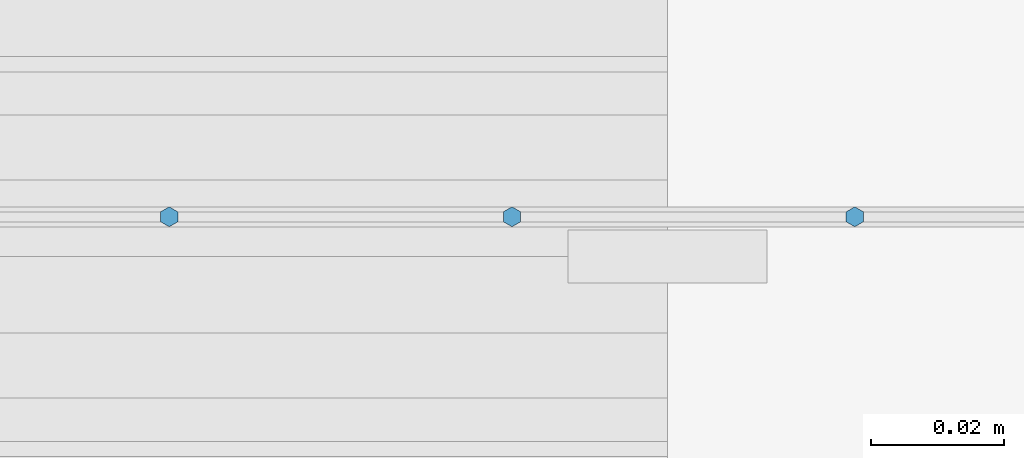
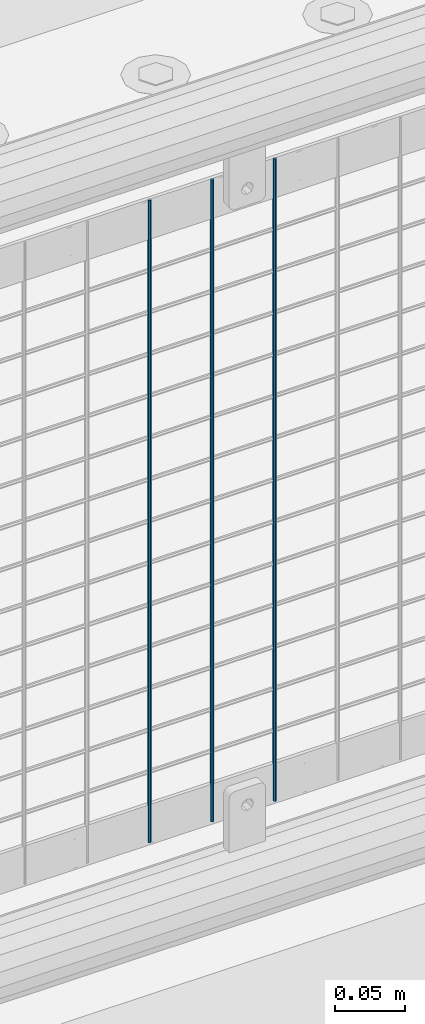
# One storey, part 81 of 240: 3 columns.
"""IFC2X3 building model written with IfcOpenShell, lengths in millimetres."""

import ifcopenshell
import ifcopenshell.guid

model = None  # the IFC model being written
_history = None  # IfcOwnerHistory: only IFC2X3 demands one
_inside = {}  # id of a spatial element -> (the spatial element, [elements in it])
_under = {}  # id of a project, library or spatial element -> (it, [spatial elements below it])
_declared = {}  # id of a project -> (the project, [libraries it declares])
_typed = {}  # id of a type object -> (the type object, [elements of that type])
_made_of = {}  # id of a material, layer set ... -> (it, [elements and type objects made of it])


def new_model(schema):
    """Start an empty IFC model of exactly this schema.

    Asked for "IFC4X3", IfcOpenShell would pick the latest addendum, in which some entities
    have other attributes; the version numbers below select the first issue.
    IFC2X3 requires an IfcOwnerHistory on every rooted entity: one is made here for all.
    """
    global model, _history
    if schema == "IFC4X3":
        model = ifcopenshell.file(schema_version=(4, 3, 0, 0))
    else:
        model = ifcopenshell.file(schema=schema)
    _inside.clear()
    _under.clear()
    _declared.clear()
    _typed.clear()
    _made_of.clear()
    _history = None
    if model.schema == "IFC2X3":
        org = make("IfcOrganization", Name="unknown")
        user = make(
            "IfcPersonAndOrganization",
            ThePerson=make("IfcPerson", FamilyName="unknown"),
            TheOrganization=org,
        )
        app = make(
            "IfcApplication",
            ApplicationDeveloper=org,
            Version="unknown",
            ApplicationFullName="unknown",
            ApplicationIdentifier="unknown",
        )
        _history = make(
            "IfcOwnerHistory",
            OwningUser=user,
            OwningApplication=app,
            ChangeAction="ADDED",
            CreationDate=0,
        )
    return model


def make(cls, **values):
    """One entity of the class cls with the attributes given. An attribute that is None is left unset."""
    return model.create_entity(
        cls, **{name: value for name, value in values.items() if value is not None}
    )


def rooted(cls, **values):
    """An entity with a GlobalId (a new one), such as an element, a storey or a relation."""
    return make(cls, GlobalId=ifcopenshell.guid.new(), OwnerHistory=_history, **values)


def si_unit(unit_type, name, prefix=None):
    """IfcSIUnit, for example si_unit("LENGTHUNIT", "METRE", prefix="MILLI")."""
    return make("IfcSIUnit", UnitType=unit_type, Prefix=prefix, Name=name)


def assignment(units):
    """IfcUnitAssignment: the units of a project."""
    return None if units is None else make("IfcUnitAssignment", Units=units)


def point(xyz):
    """IfcCartesianPoint."""
    return None if xyz is None else make("IfcCartesianPoint", Coordinates=xyz)


def direction(xyz):
    """IfcDirection."""
    return None if xyz is None else make("IfcDirection", DirectionRatios=xyz)


def frame(location, z_axis=None, x_axis=None):
    """IfcAxis2Placement3D, a coordinate frame: its origin and axes. An axis left out is left unset."""
    return make(
        "IfcAxis2Placement3D",
        Location=point(location),
        Axis=direction(z_axis),
        RefDirection=direction(x_axis),
    )


def origin_with_axes():
    """The frame at (0, 0, 0) with the z axis (0, 0, 1) and the x axis (1, 0, 0) written out."""
    return frame((0.0, 0.0, 0.0), z_axis=(0.0, 0.0, 1.0), x_axis=(1.0, 0.0, 0.0))


def place(relative_to, where):
    """IfcLocalPlacement: puts the frame where relative to a parent placement (None: the world)."""
    return make(
        "IfcLocalPlacement", PlacementRelTo=relative_to, RelativePlacement=where
    )


def context(
    kind, dimensions, precision=None, world=None, true_north=None, identifier=None
):
    """IfcGeometricRepresentationContext, for example the 3D "Model" context."""
    return make(
        "IfcGeometricRepresentationContext",
        ContextIdentifier=identifier,
        ContextType=kind,
        CoordinateSpaceDimension=dimensions,
        Precision=precision,
        WorldCoordinateSystem=world,
        TrueNorth=true_north,
    )


def subcontext(parent, identifier, kind, view, scale=None):
    """IfcGeometricRepresentationSubContext, for example "Body" below "Model"."""
    return make(
        "IfcGeometricRepresentationSubContext",
        ContextIdentifier=identifier,
        ContextType=kind,
        ParentContext=parent,
        TargetScale=scale,
        TargetView=view,
    )


def project(units=None, contexts=None):
    """IfcProject with its units and contexts."""
    return rooted(
        "IfcProject",
        Name="project",
        RepresentationContexts=contexts,
        UnitsInContext=assignment(units),
    )


def spatial(cls, under=None, at=None, **own):
    """A site, building, storey or space (cls), placed at a placement, below another one or the project."""
    s = rooted(cls, ObjectPlacement=at, **own)
    if under is not None:
        _under.setdefault(under.id(), (under, []))[1].append(s)
    return s


def faces_of(points, faces, orient=None, outer=None):
    """IfcFace entities. A face is a list of loops; a loop is a list of indices into points, from 0.

    orient and outer hold one flag for each loop. By default every Orientation is true, the
    first loop of a face is its IfcFaceOuterBound and the others are IfcFaceBound.
    """
    made = []
    for i, loops in enumerate(faces):
        bounds = []
        for j, loop in enumerate(loops):
            is_outer = j == 0 if outer is None else outer[i][j]
            bounds.append(
                make(
                    "IfcFaceOuterBound" if is_outer else "IfcFaceBound",
                    Bound=make("IfcPolyLoop", Polygon=[points[k] for k in loop]),
                    Orientation=True if orient is None else orient[i][j],
                )
            )
        made.append(make("IfcFace", Bounds=bounds))
    return made


def faceted_brep(points, faces, orient=None, outer=None, voids=None):
    """IfcFacetedBrep: a solid bounded by flat faces; with voids (closed shells), ...WithVoids."""
    shared = [point(p) for p in points]
    hull = make("IfcClosedShell", CfsFaces=faces_of(shared, faces, orient, outer))
    if voids is None:
        return make("IfcFacetedBrep", Outer=hull)
    return make(
        "IfcFacetedBrepWithVoids",
        Outer=hull,
        Voids=[
            make(cls, CfsFaces=faces_of(shared, fs, o, b)) for cls, fs, o, b in voids
        ],
    )


def shape(context_of_items, identifier, shape_type, items):
    """IfcShapeRepresentation: the items that make up one representation, for example the "Body"."""
    return make(
        "IfcShapeRepresentation",
        ContextOfItems=context_of_items,
        RepresentationIdentifier=identifier,
        RepresentationType=shape_type,
        Items=items,
    )


def material(Name=None, Category=None):
    """IfcMaterial."""
    return make("IfcMaterial", Name=Name, Category=Category)


def made_of(thing, what):
    """Note that an element or type object is made of a material, layer set ...; save() writes the relation."""
    if what is not None:
        _made_of.setdefault(what.id(), (what, []))[1].append(thing)
    return thing


def type_object(cls, material=None, **own):
    """A type object (cls), such as IfcWallType, which elements share."""
    return made_of(rooted(cls, **own), material)


def element(
    cls,
    number,
    at=None,
    inside=None,
    cuts=None,
    type_object=None,
    material=None,
    context=None,
    identifier="Body",
    shape_type=None,
    held_by="IfcProductDefinitionShape",
    body=None,
    shapes=None,
    **own,
):
    """One element of the class cls, such as IfcWall. Its Tag is "e" and its number.

    at: its placement. inside: the storey or other place that contains it. cuts: it is an
    opening in that element (IfcRelVoidsElement). A single representation is given by context,
    identifier, shape_type and body (its items); several are given by shapes. held_by: the class
    of the entity that holds the representations. save() writes the other relations.
    """
    e = rooted(cls, Tag="e%d" % number, ObjectPlacement=at, **own)
    if body is not None:
        shapes = [shape(context, identifier, shape_type, body)]
    if shapes is not None:
        e.Representation = make(held_by, Representations=shapes)
    if inside is not None:
        _inside.setdefault(inside.id(), (inside, []))[1].append(e)
    if cuts is not None:
        rooted(
            "IfcRelVoidsElement", RelatingBuildingElement=cuts, RelatedOpeningElement=e
        )
    if type_object is not None:
        _typed.setdefault(type_object.id(), (type_object, []))[1].append(e)
    return made_of(e, material)


def aggregate(whole, parts):
    """IfcRelAggregates: a whole, such as a stair, and the parts it consists of."""
    return rooted("IfcRelAggregates", RelatingObject=whole, RelatedObjects=parts)


def save(model, path):
    """Write the relations noted so far, then the file.

    IfcRelAggregates (storeys below a building ...), IfcRelContainedInSpatialStructure (elements
    in a storey), IfcRelDefinesByType, IfcRelAssociatesMaterial and IfcRelDeclares: one each for
    every whole, place, type object, material and project.
    """
    for whole, parts in _under.values():
        aggregate(whole, parts)
    for where, things in _inside.values():
        rooted(
            "IfcRelContainedInSpatialStructure",
            RelatedElements=things,
            RelatingStructure=where,
        )
    for kind, things in _typed.values():
        rooted("IfcRelDefinesByType", RelatedObjects=things, RelatingType=kind)
    for what, things in _made_of.values():
        rooted("IfcRelAssociatesMaterial", RelatedObjects=things, RelatingMaterial=what)
    for by, libraries in _declared.values():
        rooted("IfcRelDeclares", RelatingContext=by, RelatedDefinitions=libraries)
    model.write(path)


model = new_model("IFC2X3")

# Units and contexts
model_context = context("Model", 3, precision=1e-05, world=origin_with_axes())
body_context = subcontext(model_context, "Body", "Model", "MODEL_VIEW")
ifc_project = project(units=[si_unit("LENGTHUNIT", "METRE", prefix="MILLI"), si_unit("AREAUNIT", "SQUARE_METRE"), si_unit("VOLUMEUNIT", "CUBIC_METRE"), si_unit("MASSUNIT", "GRAM", prefix="KILO"), si_unit("TIMEUNIT", "SECOND"), si_unit("PLANEANGLEUNIT", "RADIAN"), si_unit("SOLIDANGLEUNIT", "STERADIAN"), si_unit("THERMODYNAMICTEMPERATUREUNIT", "DEGREE_CELSIUS"), si_unit("LUMINOUSINTENSITYUNIT", "LUMEN")], contexts=[model_context])

# Site, building, storey
site_placement = place(None, origin_with_axes())
site = spatial("IfcSite", under=ifc_project, at=site_placement, CompositionType="ELEMENT")
building_placement = place(site_placement, origin_with_axes())
building = spatial("IfcBuilding", under=site, at=building_placement, Name="Standard", CompositionType="ELEMENT")
storey_placement = place(building_placement, origin_with_axes())
storey = spatial("IfcBuildingStorey", under=building, at=storey_placement, Name="Undefined", CompositionType="ELEMENT", Elevation=0.0)

# Columns
ifc_material = material(Name="Misc_Undefined")
column_type = type_object("IfcColumnType", Name="D3", PredefinedType="NOTDEFINED")
for number, where, z_axis, x_axis in (
    (1, (48538.24, 34670.5, 353.02), (-1.0, 0.0, 0.0), (0.0, 0.0, 1.0)),
    (2, (48486.585, 34670.5, 353.02), (-1.0, 0.0, 0.0), (0.0, 0.0, 1.0)),
    (3, (48434.93, 34670.5, 353.02), (-1.0, 0.0, 0.0), (0.0, 0.0, 1.0)),
):
    element("IfcColumn", number, at=place(storey_placement, frame(where, z_axis=z_axis, x_axis=x_axis)), inside=storey, type_object=column_type, material=ifc_material, ObjectType="D3", context=body_context, shape_type="Brep", body=[
        faceted_brep([(-7.27595761418343e-12, -1.49999999999272, 0.0), (-7.27595761418343e-12, -0.749999999992724, -1.29903810567669), (560.0, -0.75, -1.29903810567339), (560.0, -1.5, 0.0), (0.0, 0.750000000007276, -1.29903810567669), (560.0, 0.75, -1.29903810567339), (0.0, 1.50000000000728, 0.0), (560.0, 1.5, 0.0), (0.0, 0.750000000007276, 1.29903810567669), (560.0, 0.75, 1.29903810567339), (-7.27595761418343e-12, -0.749999999992724, 1.29903810567669), (560.0, -0.75, 1.29903810567339)], [[[0, 1, 2, 3]], [[1, 4, 5, 2]], [[4, 6, 7, 5]], [[6, 8, 9, 7]], [[8, 10, 11, 9]], [[10, 0, 3, 11]], [[5, 7, 9, 11, 3, 2]], [[10, 8, 6, 4, 1, 0]]]),
    ])

save(model, "model.ifc")
